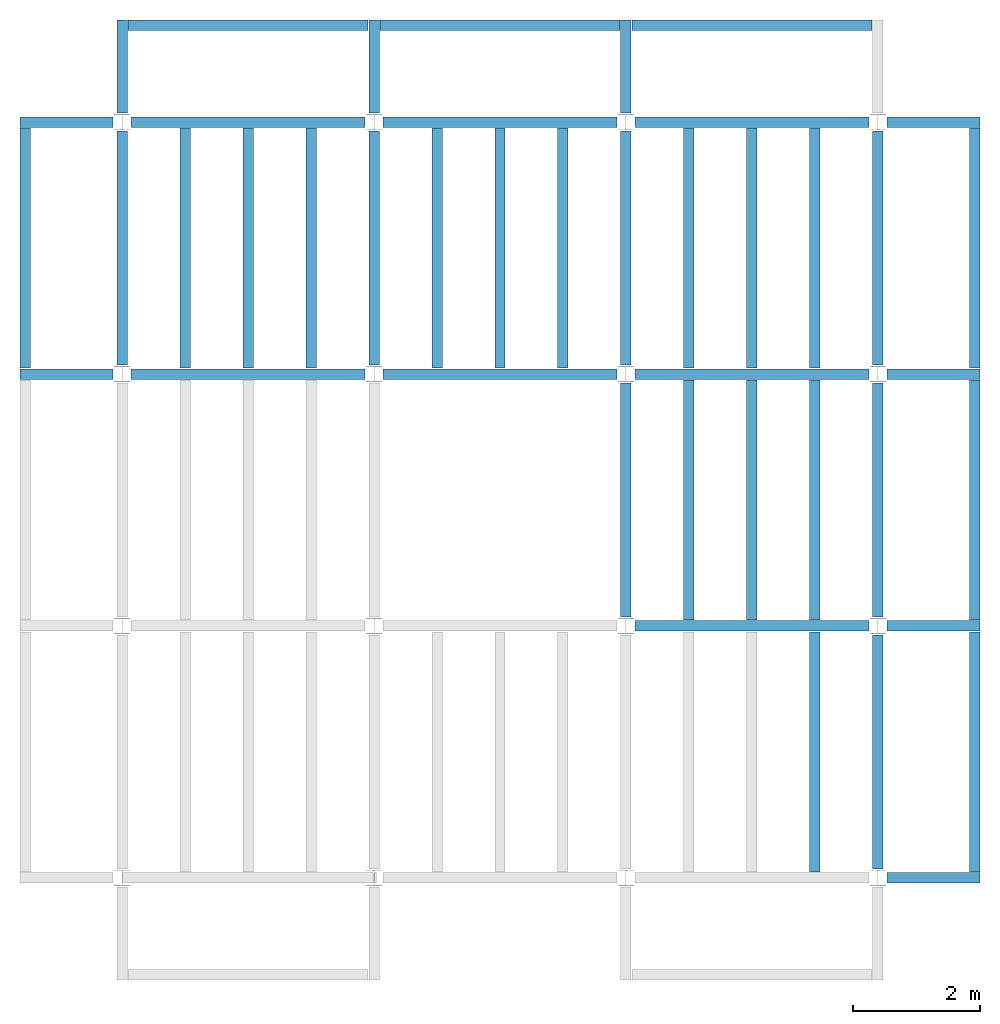
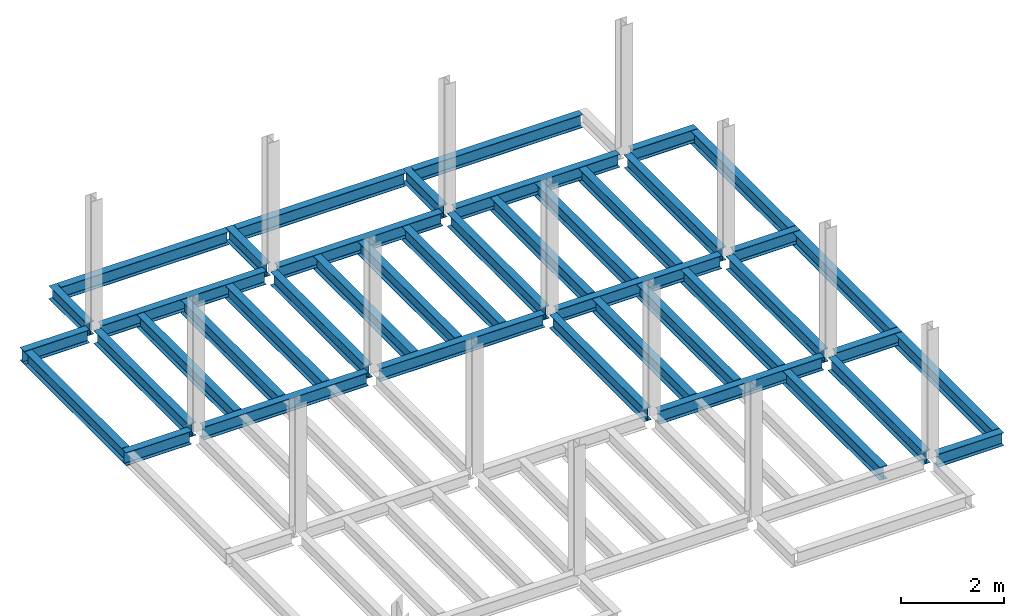
# One storey, part 2 of 3: 43 beams, 5 elements without a shape of their own.
"""IFC4 building model written with IfcOpenShell, lengths in feet."""

from ifc_helpers import new_model, entity, si_unit, converted_unit, derived_unit, direction, frame, origin, place, context, subcontext, project, spatial, line, arc, indexed_curve, outline, extrude, source, transform, mapped, material, type_object, type_shapes, element, aggregate, save


model = new_model("IFC4")

# Units and contexts
model_context = context("Model", 3, precision=0.0001, world=origin(), true_north=direction((6.123233995736766e-17, 1.0)))
plan_context = context("Plan", 3, precision=0.0001, world=origin(), true_north=direction((6.123233995736766e-17, 1.0)))
body_context = subcontext(model_context, "Body", "Model", "MODEL_VIEW")
ifc_project = project(units=[converted_unit("LENGTHUNIT", "FOOT", entity("IfcLengthMeasure", 0.3048), si_unit("LENGTHUNIT", "METRE"), dimensions=[1, 0, 0, 0, 0, 0, 0]), converted_unit("AREAUNIT", "SQUARE FOOT", entity("IfcAreaMeasure", 0.09290304), si_unit("AREAUNIT", "SQUARE_METRE"), dimensions=[2, 0, 0, 0, 0, 0, 0]), converted_unit("PLANEANGLEUNIT", "DEGREE", entity("IfcPlaneAngleMeasure", 0.017453292519943278), si_unit("PLANEANGLEUNIT", "RADIAN"), dimensions=[0, 0, 0, 0, 0, 0, 0]), converted_unit("VOLUMEUNIT", "CUBIC FOOT", entity("IfcVolumeMeasure", 0.028316846592000004), si_unit("VOLUMEUNIT", "CUBIC_METRE"), dimensions=[3, 0, 0, 0, 0, 0, 0]), si_unit("PRESSUREUNIT", "PASCAL"), derived_unit("MASSDENSITYUNIT", [(si_unit("MASSUNIT", "GRAM", prefix="KILO"), 1), (si_unit("LENGTHUNIT", "METRE"), -3)]), derived_unit("VAPORPERMEABILITYUNIT", [(si_unit("LENGTHUNIT", "METRE"), -1), (si_unit("TIMEUNIT", "SECOND"), 1)]), derived_unit("USERDEFINED", [(si_unit("MASSUNIT", "GRAM", prefix="KILO"), 1), (si_unit("LENGTHUNIT", "METRE"), 3), (si_unit("TIMEUNIT", "SECOND"), -3), (si_unit("ELECTRICCURRENTUNIT", "AMPERE"), -2)]), derived_unit("MODULUSOFELASTICITYUNIT", [(si_unit("MASSUNIT", "GRAM", prefix="KILO"), 1), (si_unit("LENGTHUNIT", "METRE"), -1), (si_unit("TIMEUNIT", "SECOND"), -2)]), derived_unit("THERMALEXPANSIONCOEFFICIENTUNIT", [(si_unit("THERMODYNAMICTEMPERATUREUNIT", "KELVIN"), -1)]), derived_unit("SPECIFICHEATCAPACITYUNIT", [(si_unit("TIMEUNIT", "SECOND"), -2), (si_unit("THERMODYNAMICTEMPERATUREUNIT", "KELVIN"), -1), (si_unit("LENGTHUNIT", "METRE"), 2)]), derived_unit("THERMALCONDUCTANCEUNIT", [(si_unit("MASSUNIT", "GRAM", prefix="KILO"), 1), (si_unit("TIMEUNIT", "SECOND"), -3), (si_unit("THERMODYNAMICTEMPERATUREUNIT", "KELVIN"), -1), (si_unit("LENGTHUNIT", "METRE"), 1)])], contexts=[model_context, plan_context])

# Site, building, storey
site_placement = place(None, origin())
site = spatial("IfcSite", under=ifc_project, at=site_placement, CompositionType="ELEMENT")
building_placement = place(site_placement, origin())
building = spatial("IfcBuilding", under=site, at=building_placement, CompositionType="ELEMENT")
storey_placement = place(building_placement, frame((0.0, 0.0, 99.875)))
storey = spatial("IfcBuildingStorey", under=building, at=storey_placement, Name="STR 11", CompositionType="ELEMENT", Elevation=99.875)

# Beams
ifc_material = material(Name="Steel ASTM A992", Category="Metal")
beam_type_1 = type_object("IfcBeamType", Name="W12X26", PredefinedType="JOIST", material=ifc_material)
shared_shape_1 = source(origin(), body_context, "Body", "SweptSolid", [
    extrude(outline(indexed_curve([(-0.27041666666666714, -0.47666666666666574), (-0.27041666666666714, -0.5083333333333351), (0.2704166666666669, -0.5083333333333351), (0.2704166666666669, -0.47666666666666574), (0.03458333333333309, -0.47666666666666574), (0.016905663803669493, -0.46934433619632937), (0.009583333333333202, -0.4516666666666659), (0.0095833333333332, 0.45166666666666705), (0.01690566380366948, 0.4693443361963307), (0.03458333333333325, 0.4766666666666671), (0.2704166666666669, 0.4766666666666671), (0.2704166666666669, 0.5083333333333312), (-0.2704166666666655, 0.5083333333333312), (-0.2704166666666655, 0.4766666666666671), (-0.034583333333333514, 0.47666666666666707), (-0.016905663803669865, 0.46934433619633054), (-0.009583333333333737, 0.45166666666666694), (-0.009583333333333735, -0.4516666666666658), (-0.01690566380367013, -0.4693443361963295), (-0.03458333333333368, -0.47666666666666574)], segments=[line(1, 2, 3, 4, 5), arc(5, 6, 7), line(7, 8), arc(8, 9, 10), line(10, 11, 12, 13, 14, 15), arc(15, 16, 17), line(17, 18), arc(18, 19, 20), line(20, 1)], self_intersect=False)), frame((-6.103346456692914, 0.0, 0.0), z_axis=(-1.0, 0.0, 0.0), x_axis=(0.0, -1.0, 0.0)), (0.0, 0.0, -1.0), 12.083333333333323),
])
type_shapes(beam_type_1, [shared_shape_1])
for number, where, name in (
    (1, (6.561679790026307, 39.0, -0.50833333333334), "W12X26"),
    (2, (6.561679790026288, 26.0, -0.50833333333334), "W12X26"),
):
    element("IfcBeam", number, at=place(storey_placement, frame(where)), inside=storey, type_object=beam_type_1, material=ifc_material, Name=name, ObjectType="W Shapes:W12X26", PredefinedType="JOIST", context=body_context, shape_type="MappedRepresentation", body=[
        mapped(shared_shape_1, transform((0.0, 0.0, 0.0), scale=1.0)),
    ])
beam_1_placement = place(storey_placement, frame((39.0, 6.56167979002612, -0.50833333333334), z_axis=(0.0, 0.0, 1.0), x_axis=(0.0, 1.0, 0.0)))
element("IfcBeam", 3, at=beam_1_placement, inside=storey, type_object=beam_type_1, material=ifc_material, Name="W12X26", ObjectType="W Shapes:W12X26", PredefinedType="JOIST", context=body_context, shape_type="MappedRepresentation", body=[
    mapped(shared_shape_1, transform((0.0, 0.0, 0.0), scale=1.0)),
])
beam_type_2 = type_object("IfcBeamType", Name="W12X26", PredefinedType="JOIST", material=ifc_material)
shared_shape_2 = source(origin(), body_context, "Body", "SweptSolid", [
    extrude(outline(indexed_curve([(-0.27041666666666714, -0.47666666666666574), (-0.27041666666666714, -0.5083333333333351), (0.2704166666666669, -0.5083333333333351), (0.2704166666666669, -0.47666666666666574), (0.03458333333333309, -0.47666666666666574), (0.016905663803669493, -0.46934433619632937), (0.009583333333333202, -0.4516666666666659), (0.0095833333333332, 0.45166666666666705), (0.01690566380366948, 0.4693443361963307), (0.03458333333333325, 0.4766666666666671), (0.2704166666666669, 0.4766666666666671), (0.2704166666666669, 0.5083333333333312), (-0.2704166666666655, 0.5083333333333312), (-0.2704166666666655, 0.4766666666666671), (-0.034583333333333514, 0.47666666666666707), (-0.016905663803669865, 0.46934433619633054), (-0.009583333333333737, 0.45166666666666694), (-0.009583333333333735, -0.4516666666666658), (-0.01690566380367013, -0.4693443361963295), (-0.03458333333333368, -0.47666666666666574)], segments=[line(1, 2, 3, 4, 5), arc(5, 6, 7), line(7, 8), arc(8, 9, 10), line(10, 11, 12, 13, 14, 15), arc(15, 16, 17), line(17, 18), arc(18, 19, 20), line(20, 1)], self_intersect=False)), frame((-6.226706036745409, 0.0, 0.0), z_axis=(-1.0, 0.0, 0.0), x_axis=(0.0, -1.0, 0.0)), (0.0, 0.0, -1.0), 12.08333333333333),
])
type_shapes(beam_type_2, [shared_shape_2])
for number, where, name in (
    (4, (19.685039370078798, 39.0, -0.50833333333334), "W12X26"),
    (5, (19.68503937007878, 26.0, -0.50833333333334), "W12X26"),
):
    element("IfcBeam", number, at=place(storey_placement, frame(where)), inside=storey, type_object=beam_type_2, material=ifc_material, Name=name, ObjectType="W Shapes:W12X26", PredefinedType="JOIST", context=body_context, shape_type="MappedRepresentation", body=[
        mapped(shared_shape_2, transform((0.0, 0.0, 0.0), scale=1.0)),
    ])
for number, where, z_axis, x_axis, name in (
    (6, (39.0, 19.685039370078613, -0.50833333333334), (0.0, 0.0, 1.0), (0.0, 1.0, 0.0), "W12X26"),
    (7, (26.0, 19.685039370078655, -0.50833333333334), (0.0, 0.0, 1.0), (0.0, 1.0, 0.0), "W12X26"),
):
    element("IfcBeam", number, at=place(storey_placement, frame(where, z_axis=z_axis, x_axis=x_axis)), inside=storey, type_object=beam_type_2, material=ifc_material, Name=name, ObjectType="W Shapes:W12X26", PredefinedType="JOIST", context=body_context, shape_type="MappedRepresentation", body=[
        mapped(shared_shape_2, transform((0.0, 0.0, 0.0), scale=1.0)),
    ])

# Assembly, beams
assembly_1_placement = place(storey_placement, origin())
assembly_1 = element("IfcElementAssembly", 8, at=assembly_1_placement, inside=storey, Name="Structural Framing System", ObjectType="Structural Beam System:Structural Framing System", AssemblyPlace="NOTDEFINED", PredefinedType="BEAM_GRID")
beam_type_3 = type_object("IfcBeamType", Name="W12X26", PredefinedType="JOIST", material=ifc_material)
shared_shape_3 = source(origin(), body_context, "Body", "SweptSolid", [
    extrude(outline(indexed_curve([(-0.27041666666666714, -0.47666666666666574), (-0.27041666666666714, -0.5083333333333351), (0.2704166666666669, -0.5083333333333351), (0.2704166666666669, -0.47666666666666574), (0.03458333333333309, -0.47666666666666574), (0.016905663803669493, -0.46934433619632937), (0.009583333333333202, -0.4516666666666659), (0.0095833333333332, 0.45166666666666705), (0.01690566380366948, 0.4693443361963307), (0.03458333333333325, 0.4766666666666671), (0.2704166666666669, 0.4766666666666671), (0.2704166666666669, 0.5083333333333312), (-0.2704166666666655, 0.5083333333333312), (-0.2704166666666655, 0.4766666666666671), (-0.034583333333333514, 0.47666666666666707), (-0.016905663803669865, 0.46934433619633054), (-0.009583333333333737, 0.45166666666666694), (-0.009583333333333735, -0.4516666666666658), (-0.01690566380367013, -0.4693443361963295), (-0.03458333333333368, -0.47666666666666574)], segments=[line(1, 2, 3, 4, 5), arc(5, 6, 7), line(7, 8), arc(8, 9, 10), line(10, 11, 12, 13, 14, 15), arc(15, 16, 17), line(17, 18), arc(18, 19, 20), line(20, 1)], self_intersect=False)), frame((-6.187916666666566, 0.0, 0.0), z_axis=(-1.0, 0.0, 0.0), x_axis=(0.0, -1.0, 0.0)), (0.0, 0.0, -1.0), 12.375833333333075),
])
type_shapes(beam_type_3, [shared_shape_3])
beam_2_placement = place(assembly_1_placement, frame((3.250000000000073, 32.49999999999969, -0.50833333333334), z_axis=(0.0, 0.0, 1.0), x_axis=(0.0, 1.0, 0.0)))
beam_2 = element("IfcBeam", 9, at=beam_2_placement, type_object=beam_type_3, material=ifc_material, Name="W12X26", ObjectType="W Shapes:W12X26", PredefinedType="JOIST", context=body_context, shape_type="MappedRepresentation", body=[
    mapped(shared_shape_3, transform((0.0, 0.0, 0.0), scale=1.0)),
])
beam_3_placement = place(assembly_1_placement, frame((6.500000000000094, 32.49999999999967, -0.50833333333334), z_axis=(0.0, 0.0, 1.0), x_axis=(0.0, 1.0, 0.0)))
beam_3 = element("IfcBeam", 10, at=beam_3_placement, type_object=beam_type_3, material=ifc_material, Name="W12X26", ObjectType="W Shapes:W12X26", PredefinedType="JOIST", context=body_context, shape_type="MappedRepresentation", body=[
    mapped(shared_shape_3, transform((0.0, 0.0, 0.0), scale=1.0)),
])
beam_4_placement = place(assembly_1_placement, frame((9.750000000000115, 32.49999999999966, -0.50833333333334), z_axis=(0.0, 0.0, 1.0), x_axis=(0.0, 1.0, 0.0)))
beam_4 = element("IfcBeam", 11, at=beam_4_placement, type_object=beam_type_3, material=ifc_material, Name="W12X26", ObjectType="W Shapes:W12X26", PredefinedType="JOIST", context=body_context, shape_type="MappedRepresentation", body=[
    mapped(shared_shape_3, transform((0.0, 0.0, 0.0), scale=1.0)),
])
aggregate(assembly_1, [beam_2, beam_3, beam_4])

assembly_2_placement = place(storey_placement, origin())
assembly_2 = element("IfcElementAssembly", 12, at=assembly_2_placement, inside=storey, Name="Structural Framing System", ObjectType="Structural Beam System:Structural Framing System", AssemblyPlace="NOTDEFINED", PredefinedType="BEAM_GRID")
beam_5_placement = place(assembly_2_placement, frame((16.25000000000014, 32.499999999999645, -0.50833333333334), z_axis=(0.0, 0.0, 1.0), x_axis=(0.0, 1.0, 0.0)))
beam_5 = element("IfcBeam", 13, at=beam_5_placement, type_object=beam_type_3, material=ifc_material, Name="W12X26", ObjectType="W Shapes:W12X26", PredefinedType="JOIST", context=body_context, shape_type="MappedRepresentation", body=[
    mapped(shared_shape_3, transform((0.0, 0.0, 0.0), scale=1.0)),
])
beam_6_placement = place(assembly_2_placement, frame((19.50000000000014, 32.49999999999963, -0.50833333333334), z_axis=(0.0, 0.0, 1.0), x_axis=(0.0, 1.0, 0.0)))
beam_6 = element("IfcBeam", 14, at=beam_6_placement, type_object=beam_type_3, material=ifc_material, Name="W12X26", ObjectType="W Shapes:W12X26", PredefinedType="JOIST", context=body_context, shape_type="MappedRepresentation", body=[
    mapped(shared_shape_3, transform((0.0, 0.0, 0.0), scale=1.0)),
])
beam_7_placement = place(assembly_2_placement, frame((22.750000000000142, 32.499999999999616, -0.50833333333334), z_axis=(0.0, 0.0, 1.0), x_axis=(0.0, 1.0, 0.0)))
beam_7 = element("IfcBeam", 15, at=beam_7_placement, type_object=beam_type_3, material=ifc_material, Name="W12X26", ObjectType="W Shapes:W12X26", PredefinedType="JOIST", context=body_context, shape_type="MappedRepresentation", body=[
    mapped(shared_shape_3, transform((0.0, 0.0, 0.0), scale=1.0)),
])
aggregate(assembly_2, [beam_5, beam_6, beam_7])

# Assembly, beam
assembly_3_placement = place(storey_placement, origin())
assembly_3 = element("IfcElementAssembly", 16, at=assembly_3_placement, inside=storey, Name="Structural Framing System", ObjectType="Structural Beam System:Structural Framing System", AssemblyPlace="NOTDEFINED", PredefinedType="BEAM_GRID")
beam_8_placement = place(assembly_3_placement, frame((35.7500000000001, 6.499999999999728, -0.50833333333334), z_axis=(0.0, 0.0, 1.0), x_axis=(0.0, 1.0, 0.0)))
beam_8 = element("IfcBeam", 17, at=beam_8_placement, type_object=beam_type_3, material=ifc_material, Name="W12X26", ObjectType="W Shapes:W12X26", PredefinedType="JOIST", context=body_context, shape_type="MappedRepresentation", body=[
    mapped(shared_shape_3, transform((0.0, 0.0, 0.0), scale=1.0)),
])
aggregate(assembly_3, [beam_8])

# Assembly, beams
assembly_4_placement = place(storey_placement, origin())
assembly_4 = element("IfcElementAssembly", 18, at=assembly_4_placement, inside=storey, Name="Structural Framing System", ObjectType="Structural Beam System:Structural Framing System", AssemblyPlace="NOTDEFINED", PredefinedType="BEAM_GRID")
beam_9_placement = place(assembly_4_placement, frame((29.25000000000012, 19.499999999999595, -0.50833333333334), z_axis=(0.0, 0.0, 1.0), x_axis=(0.0, 1.0, 0.0)))
beam_9 = element("IfcBeam", 19, at=beam_9_placement, type_object=beam_type_3, material=ifc_material, Name="W12X26", ObjectType="W Shapes:W12X26", PredefinedType="JOIST", context=body_context, shape_type="MappedRepresentation", body=[
    mapped(shared_shape_3, transform((0.0, 0.0, 0.0), scale=1.0)),
])
beam_10_placement = place(assembly_4_placement, frame((32.500000000000114, 19.499999999999588, -0.50833333333334), z_axis=(0.0, 0.0, 1.0), x_axis=(0.0, 1.0, 0.0)))
beam_10 = element("IfcBeam", 20, at=beam_10_placement, type_object=beam_type_3, material=ifc_material, Name="W12X26", ObjectType="W Shapes:W12X26", PredefinedType="JOIST", context=body_context, shape_type="MappedRepresentation", body=[
    mapped(shared_shape_3, transform((0.0, 0.0, 0.0), scale=1.0)),
])
beam_11_placement = place(assembly_4_placement, frame((35.750000000000114, 19.499999999999574, -0.50833333333334), z_axis=(0.0, 0.0, 1.0), x_axis=(0.0, 1.0, 0.0)))
beam_11 = element("IfcBeam", 21, at=beam_11_placement, type_object=beam_type_3, material=ifc_material, Name="W12X26", ObjectType="W Shapes:W12X26", PredefinedType="JOIST", context=body_context, shape_type="MappedRepresentation", body=[
    mapped(shared_shape_3, transform((0.0, 0.0, 0.0), scale=1.0)),
])
aggregate(assembly_4, [beam_9, beam_10, beam_11])

assembly_5_placement = place(storey_placement, origin())
assembly_5 = element("IfcElementAssembly", 22, at=assembly_5_placement, inside=storey, Name="Structural Framing System", ObjectType="Structural Beam System:Structural Framing System", AssemblyPlace="NOTDEFINED", PredefinedType="BEAM_GRID")
beam_12_placement = place(assembly_5_placement, frame((29.250000000000142, 32.4999999999996, -0.50833333333334), z_axis=(0.0, 0.0, 1.0), x_axis=(0.0, 1.0, 0.0)))
beam_12 = element("IfcBeam", 23, at=beam_12_placement, type_object=beam_type_3, material=ifc_material, Name="W12X26", ObjectType="W Shapes:W12X26", PredefinedType="JOIST", context=body_context, shape_type="MappedRepresentation", body=[
    mapped(shared_shape_3, transform((0.0, 0.0, 0.0), scale=1.0)),
])
beam_13_placement = place(assembly_5_placement, frame((32.50000000000014, 32.49999999999959, -0.50833333333334), z_axis=(0.0, 0.0, 1.0), x_axis=(0.0, 1.0, 0.0)))
beam_13 = element("IfcBeam", 24, at=beam_13_placement, type_object=beam_type_3, material=ifc_material, Name="W12X26", ObjectType="W Shapes:W12X26", PredefinedType="JOIST", context=body_context, shape_type="MappedRepresentation", body=[
    mapped(shared_shape_3, transform((0.0, 0.0, 0.0), scale=1.0)),
])
beam_14_placement = place(assembly_5_placement, frame((35.75000000000014, 32.499999999999574, -0.50833333333334), z_axis=(0.0, 0.0, 1.0), x_axis=(0.0, 1.0, 0.0)))
beam_14 = element("IfcBeam", 25, at=beam_14_placement, type_object=beam_type_3, material=ifc_material, Name="W12X26", ObjectType="W Shapes:W12X26", PredefinedType="JOIST", context=body_context, shape_type="MappedRepresentation", body=[
    mapped(shared_shape_3, transform((0.0, 0.0, 0.0), scale=1.0)),
])
aggregate(assembly_5, [beam_12, beam_13, beam_14])

# Beams
for number, where, z_axis, x_axis, name in (
    (26, (-5.0, 32.4999999999997, -0.50833333333334), (0.0, 0.0, 1.0), (0.0, 1.0, 0.0), "W12X26"),
    (27, (44.0, 6.4999999999997, -0.50833333333334), (0.0, 0.0, 1.0), (0.0, 1.0, 0.0), "W12X26"),
    (28, (44.0, 19.499999999999545, -0.50833333333334), (0.0, 0.0, 1.0), (0.0, 1.0, 0.0), "W12X26"),
    (29, (44.0, 32.499999999999545, -0.50833333333334), (0.0, 0.0, 1.0), (0.0, 1.0, 0.0), "W12X26"),
):
    element("IfcBeam", number, at=place(storey_placement, frame(where, z_axis=z_axis, x_axis=x_axis)), inside=storey, type_object=beam_type_3, material=ifc_material, Name=name, ObjectType="W Shapes:W12X26", PredefinedType="JOIST", context=body_context, shape_type="MappedRepresentation", body=[
        mapped(shared_shape_3, transform((0.0, 0.0, 0.0), scale=1.0)),
    ])
beam_15_placement = place(storey_placement, frame((6.5000000000001625, 44.0, -0.50833333333334)))
element("IfcBeam", 30, at=beam_15_placement, inside=storey, type_object=beam_type_3, material=ifc_material, Name="W Shapes:W12X26", ObjectType="W Shapes:W12X26", PredefinedType="JOIST", context=body_context, shape_type="MappedRepresentation", body=[
    mapped(shared_shape_3, transform((0.0, 0.0, 0.0), scale=1.0)),
])
beam_type_4 = type_object("IfcBeamType", Name="W12X26", PredefinedType="JOIST", material=ifc_material)
shared_shape_4 = source(origin(), body_context, "Body", "SweptSolid", [
    extrude(outline(indexed_curve([(-0.27041666666666714, -0.47666666666666574), (-0.27041666666666714, -0.5083333333333351), (0.2704166666666669, -0.5083333333333351), (0.2704166666666669, -0.47666666666666574), (0.03458333333333309, -0.47666666666666574), (0.016905663803669493, -0.46934433619632937), (0.009583333333333202, -0.4516666666666659), (0.0095833333333332, 0.45166666666666705), (0.01690566380366948, 0.4693443361963307), (0.03458333333333325, 0.4766666666666671), (0.2704166666666669, 0.4766666666666671), (0.2704166666666669, 0.5083333333333312), (-0.2704166666666655, 0.5083333333333312), (-0.2704166666666655, 0.4766666666666671), (-0.034583333333333514, 0.47666666666666707), (-0.016905663803669865, 0.46934433619633054), (-0.009583333333333737, 0.45166666666666694), (-0.009583333333333735, -0.4516666666666658), (-0.01690566380367013, -0.4693443361963295), (-0.03458333333333368, -0.47666666666666574)], segments=[line(1, 2, 3, 4, 5), arc(5, 6, 7), line(7, 8), arc(8, 9, 10), line(10, 11, 12, 13, 14, 15), arc(15, 16, 17), line(17, 18), arc(18, 19, 20), line(20, 1)], self_intersect=False)), frame((-6.165026246719308, 0.0, 0.0), z_axis=(-1.0, 0.0, 0.0), x_axis=(0.0, -1.0, 0.0)), (0.0, 0.0, -1.0), 12.08333333333334),
])
type_shapes(beam_type_4, [shared_shape_4])
for number, where, name in (
    (31, (32.6233595800526, 39.0, -0.50833333333334), "W12X26"),
    (32, (32.62335958005258, 26.0, -0.50833333333334), "W12X26"),
    (33, (32.62335958005255, 13.0, -0.50833333333334), "W12X26"),
):
    element("IfcBeam", number, at=place(storey_placement, frame(where)), inside=storey, type_object=beam_type_4, material=ifc_material, Name=name, ObjectType="W Shapes:W12X26", PredefinedType="JOIST", context=body_context, shape_type="MappedRepresentation", body=[
        mapped(shared_shape_4, transform((0.0, 0.0, 0.0), scale=1.0)),
    ])
for number, where, z_axis, x_axis, name in (
    (34, (39.0, 32.62335958005221, -0.50833333333334), (0.0, 0.0, 1.0), (0.0, 1.0, 0.0), "W12X26"),
    (35, (26.0, 32.62335958005225, -0.50833333333334), (0.0, 0.0, 1.0), (0.0, 1.0, 0.0), "W12X26"),
    (36, (13.0, 32.623359580052295, -0.50833333333334), (0.0, 0.0, 1.0), (0.0, 1.0, 0.0), "W12X26"),
    (37, (0.0, 32.62335958005234, -0.50833333333334), (0.0, 0.0, 1.0), (0.0, 1.0, 0.0), "W12X26"),
):
    element("IfcBeam", number, at=place(storey_placement, frame(where, z_axis=z_axis, x_axis=x_axis)), inside=storey, type_object=beam_type_4, material=ifc_material, Name=name, ObjectType="W Shapes:W12X26", PredefinedType="JOIST", context=body_context, shape_type="MappedRepresentation", body=[
        mapped(shared_shape_4, transform((0.0, 0.0, 0.0), scale=1.0)),
    ])
beam_type_5 = type_object("IfcBeamType", Name="W12X26", PredefinedType="JOIST", material=ifc_material)
shared_shape_5 = source(origin(), body_context, "Body", "SweptSolid", [
    extrude(outline(indexed_curve([(0.47666666666666574, -0.2704166666666672), (0.5083333333333351, -0.2704166666666672), (0.5083333333333351, 0.27041666666666686), (0.47666666666666574, 0.27041666666666686), (0.47666666666666574, 0.03458333333333307), (0.46934433619632937, 0.016905663803669473), (0.4516666666666659, 0.00958333333333318), (-0.45166666666666705, 0.00958333333333318), (-0.4693443361963307, 0.01690566380366946), (-0.4766666666666671, 0.03458333333333323), (-0.4766666666666671, 0.27041666666666686), (-0.5083333333333312, 0.27041666666666686), (-0.5083333333333312, -0.27041666666666553), (-0.4766666666666671, -0.27041666666666553), (-0.47666666666666707, -0.034583333333333535), (-0.46934433619633054, -0.016905663803669885), (-0.45166666666666694, -0.00958333333333376), (0.4516666666666658, -0.009583333333333756), (0.4693443361963295, -0.01690566380367015), (0.47666666666666574, -0.0345833333333337)], segments=[line(1, 2, 3, 4, 5), arc(5, 6, 7), line(7, 8), arc(8, 9, 10), line(10, 11, 12, 13, 14, 15), arc(15, 16, 17), line(17, 18), arc(18, 19, 20), line(20, 1)], self_intersect=False)), frame((-2.0416666666666208, 0.0, 0.0), z_axis=(1.0, 0.0, 0.0), x_axis=(0.0, 0.0, -1.0)), (0.0, 0.0, 1.0), 4.812083333333336),
])
type_shapes(beam_type_5, [shared_shape_5])
for number, where, z_axis, x_axis, name in (
    (38, (-2.4999999999998104, 39.0, -0.50833333333334), (0.0, 0.0, 1.0), (-1.0, 0.0, 0.0), "W12X26"),
    (39, (-2.4999999999998317, 26.0, -0.50833333333334), (0.0, 0.0, 1.0), (-1.0, 0.0, 0.0), "W12X26"),
):
    element("IfcBeam", number, at=place(storey_placement, frame(where, z_axis=z_axis, x_axis=x_axis)), inside=storey, type_object=beam_type_5, material=ifc_material, Name=name, ObjectType="W Shapes:W12X26", PredefinedType="JOIST", context=body_context, shape_type="MappedRepresentation", body=[
        mapped(shared_shape_5, transform((0.0, 0.0, 0.0), scale=1.0)),
    ])
beam_type_6 = type_object("IfcBeamType", Name="W12X26", PredefinedType="JOIST", material=ifc_material)
shared_shape_6 = source(origin(), body_context, "Body", "SweptSolid", [
    extrude(outline(indexed_curve([(0.47666666666666574, -0.2704166666666672), (0.5083333333333351, -0.2704166666666672), (0.5083333333333351, 0.27041666666666686), (0.47666666666666574, 0.27041666666666686), (0.47666666666666574, 0.03458333333333307), (0.46934433619632937, 0.016905663803669473), (0.4516666666666659, 0.00958333333333318), (-0.45166666666666705, 0.00958333333333318), (-0.4693443361963307, 0.01690566380366946), (-0.4766666666666671, 0.03458333333333323), (-0.4766666666666671, 0.27041666666666686), (-0.5083333333333312, 0.27041666666666686), (-0.5083333333333312, -0.27041666666666553), (-0.4766666666666671, -0.27041666666666553), (-0.47666666666666707, -0.034583333333333535), (-0.46934433619633054, -0.016905663803669885), (-0.45166666666666694, -0.00958333333333376), (0.4516666666666658, -0.009583333333333756), (0.4693443361963295, -0.01690566380367015), (0.47666666666666574, -0.0345833333333337)], segments=[line(1, 2, 3, 4, 5), arc(5, 6, 7), line(7, 8), arc(8, 9, 10), line(10, 11, 12, 13, 14, 15), arc(15, 16, 17), line(17, 18), arc(18, 19, 20), line(20, 1)], self_intersect=False)), frame((-2.77041666666672, 0.0, 0.0), z_axis=(1.0, 0.0, 0.0), x_axis=(0.0, 0.0, -1.0)), (0.0, 0.0, 1.0), 4.812083333333389),
])
type_shapes(beam_type_6, [shared_shape_6])
for number, where, z_axis, x_axis, name in (
    (40, (41.50000000000013, 26.0, -0.50833333333334), (0.0, 0.0, 1.0), (-1.0, 0.0, 0.0), "W12X26"),
    (41, (41.50000000000011, 13.0, -0.50833333333334), (0.0, 0.0, 1.0), (-1.0, 0.0, 0.0), "W12X26"),
    (42, (41.500000000000085, 0.0, -0.50833333333334), (0.0, 0.0, 1.0), (-1.0, 0.0, 0.0), "W12X26"),
    (43, (13.0, 41.49999999999965, -0.50833333333334), (0.0, 0.0, 1.0), (0.0, -1.0, 0.0), "W12X26"),
    (44, (0.0, 41.499999999999694, -0.50833333333334), (0.0, 0.0, 1.0), (0.0, -1.0, 0.0), "W12X26"),
    (45, (41.50000000000015, 39.0, -0.50833333333334), (0.0, 0.0, 1.0), (-1.0, 0.0, 0.0), "W12X26"),
):
    element("IfcBeam", number, at=place(storey_placement, frame(where, z_axis=z_axis, x_axis=x_axis)), inside=storey, type_object=beam_type_6, material=ifc_material, Name=name, ObjectType="W Shapes:W12X26", PredefinedType="JOIST", context=body_context, shape_type="MappedRepresentation", body=[
        mapped(shared_shape_6, transform((0.0, 0.0, 0.0), scale=1.0)),
    ])
beam_type_7 = type_object("IfcBeamType", Name="W12X26", PredefinedType="JOIST", material=ifc_material)
shared_shape_7 = source(origin(), body_context, "Body", "SweptSolid", [
    extrude(outline(indexed_curve([(0.47666666666666574, -0.2704166666666672), (0.5083333333333351, -0.2704166666666672), (0.5083333333333351, 0.27041666666666686), (0.47666666666666574, 0.27041666666666686), (0.47666666666666574, 0.03458333333333307), (0.46934433619632937, 0.016905663803669473), (0.4516666666666659, 0.00958333333333318), (-0.45166666666666705, 0.00958333333333318), (-0.4693443361963307, 0.01690566380366946), (-0.4766666666666671, 0.03458333333333323), (-0.4766666666666671, 0.27041666666666686), (-0.5083333333333312, 0.27041666666666686), (-0.5083333333333312, -0.27041666666666553), (-0.4766666666666671, -0.27041666666666553), (-0.47666666666666707, -0.034583333333333535), (-0.46934433619633054, -0.016905663803669885), (-0.45166666666666694, -0.00958333333333376), (0.4516666666666658, -0.009583333333333756), (0.4693443361963295, -0.01690566380367015), (0.47666666666666574, -0.0345833333333337)], segments=[line(1, 2, 3, 4, 5), arc(5, 6, 7), line(7, 8), arc(8, 9, 10), line(10, 11, 12, 13, 14, 15), arc(15, 16, 17), line(17, 18), arc(18, 19, 20), line(20, 1)], self_intersect=False)), frame((-6.187916666666685, 0.0, 0.0), z_axis=(1.0, 0.0, 0.0), x_axis=(0.0, 0.0, -1.0)), (0.0, 0.0, 1.0), 12.375833333333318),
])
type_shapes(beam_type_7, [shared_shape_7])
beam_16_placement = place(storey_placement, frame((19.500000000000142, 44.0, -0.50833333333334), z_axis=(0.0, 0.0, 1.0), x_axis=(-1.0, 0.0, 0.0)))
element("IfcBeam", 46, at=beam_16_placement, inside=storey, type_object=beam_type_7, material=ifc_material, Name="W Shapes:W12X26", ObjectType="W Shapes:W12X26", PredefinedType="JOIST", context=body_context, shape_type="MappedRepresentation", body=[
    mapped(shared_shape_7, transform((0.0, 0.0, 0.0), scale=1.0)),
])
beam_type_8 = type_object("IfcBeamType", Name="W12X26", PredefinedType="JOIST", material=ifc_material)
shared_shape_8 = source(origin(), body_context, "Body", "SweptSolid", [
    extrude(outline(indexed_curve([(-0.2704166666666694, -0.50833333333334), (0.27041666666666586, -0.50833333333334), (0.2704166666666623, -0.4766666666666737), (0.034583333333333854, -0.4766666666666879), (0.016905663803669313, -0.4693443361963432), (0.009583333333335275, -0.4516666666666822), (0.009583333333335275, 0.4516666666666538), (0.016905663803669313, 0.46934433619631477), (0.034583333333333854, 0.47666666666665947), (0.2704166666666694, 0.47666666666665947), (0.27041666666666586, 0.5083333333333258), (-0.27041666666666586, 0.5083333333333258), (-0.27041666666666586, 0.47666666666665947), (-0.0345833333333303, 0.47666666666665947), (-0.01690566380366576, 0.46934433619631477), (-0.009583333333331723, 0.4516666666666538), (-0.009583333333331723, -0.4516666666666822), (-0.01690566380366576, -0.4693443361963432), (-0.034583333333333854, -0.4766666666666737), (-0.27041666666666586, -0.4766666666666737)], segments=[line(1, 2, 3, 4), arc(4, 5, 6), line(6, 7), arc(7, 8, 9), line(9, 10, 11, 12, 13, 14), arc(14, 15, 16), line(16, 17), arc(17, 18, 19), line(19, 20, 1)], self_intersect=False)), frame((26.0, 44.27041666666632, 99.36666666666663), z_axis=(0.0, -1.0, 0.0), x_axis=(-1.0, 0.0, 0.0)), (0.0, 0.0, 1.0), 4.812083333333393),
])
type_shapes(beam_type_8, [shared_shape_8])
beam_17_placement = place(storey_placement, frame((0.0, 0.0, -99.875)))
element("IfcBeam", 47, at=beam_17_placement, inside=storey, type_object=beam_type_8, material=ifc_material, Name="W12X26", ObjectType="W Shapes:W12X26", PredefinedType="JOIST", context=body_context, shape_type="MappedRepresentation", body=[
    mapped(shared_shape_8, transform((0.0, 0.0, 0.0), scale=1.0)),
])
beam_type_9 = type_object("IfcBeamType", Name="W12X26", PredefinedType="JOIST", material=ifc_material)
shared_shape_9 = source(origin(), body_context, "Body", "SweptSolid", [
    extrude(outline(indexed_curve([(-0.5083333333333258, -0.2704166666666694), (-0.47666666666665947, -0.2704166666666694), (-0.4766666666666737, -0.03458333333333741), (-0.469344336196329, -0.01690566380367642), (-0.451666666666668, -0.009583333333338828), (0.451666666666668, -0.009583333333338828), (0.469344336196329, -0.01690566380367642), (0.4766666666666737, -0.03458333333333741), (0.4766666666666737, -0.2704166666666694), (0.50833333333334, -0.2704166666666694), (0.50833333333334, 0.2704166666666623), (0.4766666666666737, 0.2704166666666623), (0.4766666666666737, 0.0345833333333303), (0.469344336196329, 0.016905663803669313), (0.451666666666668, 0.009583333333331723), (-0.451666666666668, 0.009583333333331723), (-0.469344336196329, 0.016905663803669313), (-0.47666666666665947, 0.0345833333333303), (-0.47666666666665947, 0.2704166666666623), (-0.5083333333333258, 0.2704166666666623)], segments=[line(1, 2, 3), arc(3, 4, 5), line(5, 6), arc(6, 7, 8), line(8, 9, 10, 11, 12, 13), arc(13, 14, 15), line(15, 16), arc(16, 17, 18), line(18, 19, 20, 1)], self_intersect=False)), frame((26.312083333333604, 44.0, 99.36666666666665), z_axis=(1.0, 0.0, 0.0), x_axis=(0.0, 0.0, -1.0)), (0.0, 0.0, 1.0), 12.375833333333079),
])
type_shapes(beam_type_9, [shared_shape_9])
beam_18_placement = place(storey_placement, frame((0.0, 0.0, -99.875)))
element("IfcBeam", 48, at=beam_18_placement, inside=storey, type_object=beam_type_9, material=ifc_material, Name="W Shapes:W12X26", ObjectType="W Shapes:W12X26", PredefinedType="JOIST", context=body_context, shape_type="MappedRepresentation", body=[
    mapped(shared_shape_9, transform((0.0, 0.0, 0.0), scale=1.0)),
])

save(model, "model.ifc")
